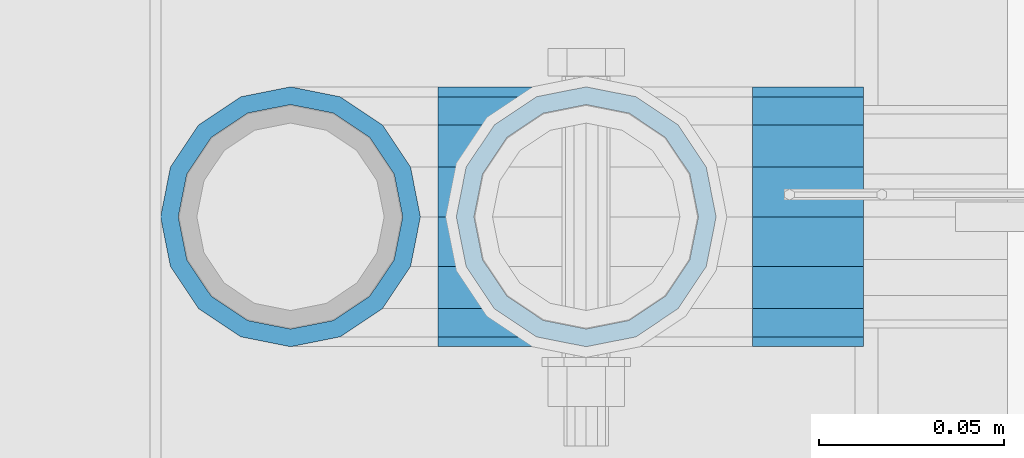
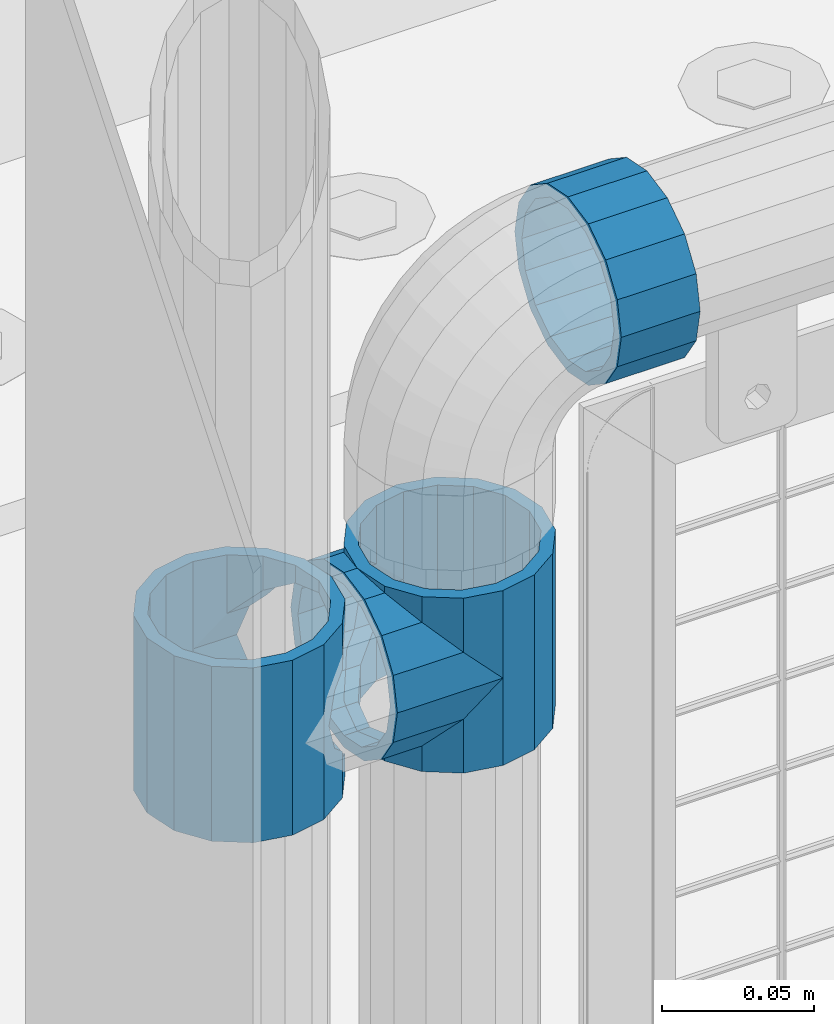
# One storey, part 145 of 247: 4 beams.
"""IFC2X3 building model written with IfcOpenShell, lengths in millimetres."""

from ifc_helpers import new_model, si_unit, frame, origin_with_axes, place, context, subcontext, project, spatial, faceted_brep, material, type_object, element, save


model = new_model("IFC2X3")

# Units and contexts
model_context = context("Model", 3, precision=1e-05, world=origin_with_axes())
body_context = subcontext(model_context, "Body", "Model", "MODEL_VIEW")
ifc_project = project(units=[si_unit("LENGTHUNIT", "METRE", prefix="MILLI"), si_unit("AREAUNIT", "SQUARE_METRE"), si_unit("VOLUMEUNIT", "CUBIC_METRE"), si_unit("MASSUNIT", "GRAM", prefix="KILO"), si_unit("TIMEUNIT", "SECOND"), si_unit("PLANEANGLEUNIT", "RADIAN"), si_unit("SOLIDANGLEUNIT", "STERADIAN"), si_unit("THERMODYNAMICTEMPERATUREUNIT", "DEGREE_CELSIUS"), si_unit("LUMINOUSINTENSITYUNIT", "LUMEN")], contexts=[model_context])

# Site, building, storey
site_placement = place(None, origin_with_axes())
site = spatial("IfcSite", under=ifc_project, at=site_placement, CompositionType="ELEMENT")
building_placement = place(site_placement, origin_with_axes())
building = spatial("IfcBuilding", under=site, at=building_placement, Name="Standard", CompositionType="ELEMENT")
storey_placement = place(building_placement, origin_with_axes())
storey = spatial("IfcBuildingStorey", under=building, at=storey_placement, Name="Undefined", CompositionType="ELEMENT", Elevation=0.0)

# Beams
ifc_material = material(Name="Misc_Undefined")
beam_type = type_object("IfcBeamType", PredefinedType="NOTDEFINED")
beam_1_placement = place(storey_placement, frame((621.0, 7664.5, 848.67), z_axis=(0.0, 1.0, 0.0), x_axis=(-1.0, 0.0, 0.0)))
element("IfcBeam", 1, at=beam_1_placement, inside=storey, type_object=beam_type, material=ifc_material, context=body_context, shape_type="Brep", body=[
    faceted_brep([(0.0, 0.0, -35.1499999999996), (13.4513226476338, -13.4513226476329, -32.4743655677721), (13.4513226476338, 13.4513226476329, -32.4743655677721), (27.1226768591096, -21.4606908090117, 21.4606908090118), (32.4743655677721, -26.8123795176755, 13.4513226476329), (32.4743655677721, -32.4743655677717, 13.4513226476329), (24.8548033587067, -24.8548033587072, 24.8548033587067), (24.8548033587067, -16.3810424080045, 24.8548033587067), (32.8397438117172, -28.0397438117175, 11.6144421722802), (35.1499999999996, -30.35, 0.0), (35.1499999999996, -35.15, 0.0), (32.4743655677721, -26.8123795176766, -13.4513226476329), (32.4743655677721, -32.4743655677717, -13.4513226476329), (32.8397438117172, -28.0397438117175, -11.6144421722802), (24.8548033587067, -16.3810424080045, -24.8548033587067), (24.8548033587067, -24.8548033587072, -24.8548033587067), (27.1226768591059, -21.4606908090117, -21.4606908090118), (20.0882031229885, -11.6144421722805, -28.0397438117179), (16.6306603983739, 0.0, -30.3500000000004), (20.0882031229885, 11.6144421722805, -28.0397438117179), (24.8548033587067, 16.3810424080029, -24.8548033587067), (24.8548033587067, 24.8548033587072, -24.8548033587067), (27.1226768591059, 21.4606908090117, -21.4606908090118), (32.4743655677721, 26.8123795176755, -13.4513226476329), (32.4743655677721, 32.4743655677717, -13.4513226476329), (32.8397438117172, 28.0397438117175, -11.6144421722802), (35.1499999999996, 30.35, 0.0), (35.1499999999996, 35.15, 0.0), (32.8397438117172, 28.0397438117175, 11.6144421722802), (32.4743655677721, 26.8123795176755, 13.4513226476329), (32.4743655677721, 32.4743655677717, 13.4513226476329), (27.1226768591096, 21.4606908090117, 21.4606908090118), (24.8548033587067, 16.3810424080046, 24.8548033587067), (24.8548033587067, 24.8548033587072, 24.8548033587067), (0.0, 0.0, 35.1499999999996), (13.4513226476338, 13.4513226476329, 32.4743655677721), (13.4513226476338, -13.4513226476329, 32.4743655677721), (20.0882031229812, 11.6144421722805, 28.0397438117179), (16.6306603983649, 0.0, 30.3500000000004), (20.0882031229812, -11.6144421722805, 28.0397438117179), (40.1500000000015, -35.15, 0.0), (40.1500000000015, -32.4743655677717, 13.4513226476329), (40.1500000000015, -24.8548033587072, 24.8548033587067), (40.1500000000015, -13.4513226476329, 32.4743655677721), (40.1500000000015, 0.0, 35.1499999999996), (40.1500000000015, -24.8548033587072, -24.8548033587067), (40.1500000000015, -32.4743655677717, -13.4513226476329), (40.1500000000015, -13.4513226476329, -32.4743655677721), (40.1500000000015, 0.0, -35.1499999999996), (40.1500000000015, 13.4513226476329, -32.4743655677721), (40.1500000000015, 24.8548033587072, -24.8548033587067), (40.1500000000015, 32.4743655677717, -13.4513226476329), (40.1500000000015, 35.15, 0.0), (40.1500000000015, 32.4743655677717, 13.4513226476329), (40.1500000000015, 24.8548033587072, 24.8548033587067), (40.1500000000015, 13.4513226476329, 32.4743655677721), (40.1500000000015, -21.4606908090117, 21.4606908090118), (40.1500000000015, -11.6144421722805, 28.0397438117179), (40.1500000000015, 0.0, 30.3500000000004), (40.1500000000015, 11.6144421722805, 28.0397438117179), (40.1500000000015, 21.4606908090117, 21.4606908090118), (40.1500000000015, 28.0397438117175, 11.6144421722802), (40.1500000000015, 30.35, 0.0), (40.1500000000015, 28.0397438117175, -11.6144421722802), (40.1500000000015, 21.4606908090117, -21.4606908090118), (40.1500000000015, 11.6144421722805, -28.0397438117179), (40.1500000000015, 0.0, -30.3500000000004), (40.1500000000015, -11.6144421722805, -28.0397438117179), (40.1500000000015, -21.4606908090117, -21.4606908090118), (40.1500000000015, -28.0397438117175, -11.6144421722802), (40.1500000000015, -30.35, 0.0), (40.1500000000015, -28.0397438117175, 11.6144421722802)], [[[0, 1, 2]], [[3, 4, 5, 6, 7]], [[8, 9, 10, 5, 4]], [[11, 12, 10, 9, 13]], [[14, 15, 12, 11, 16]], [[2, 1, 15, 14, 17, 18, 19, 20, 21]], [[21, 20, 22, 23, 24]], [[24, 23, 25, 26, 27]], [[27, 26, 28, 29, 30]], [[30, 29, 31, 32, 33]], [[34, 35, 36]], [[33, 32, 37, 38, 39, 7, 6, 36, 35]], [[40, 41, 5, 10]], [[41, 42, 6, 5]], [[42, 43, 36, 6]], [[43, 44, 34, 36]], [[45, 46, 12, 15]], [[47, 45, 15, 1]], [[48, 47, 1, 0]], [[49, 48, 0, 2]], [[50, 49, 2, 21]], [[51, 50, 21, 24]], [[52, 51, 24, 27]], [[53, 52, 27, 30]], [[54, 53, 30, 33]], [[55, 54, 33, 35]], [[44, 55, 35, 34]], [[46, 40, 10, 12]], [[45, 47, 48, 49, 50, 51, 52, 53, 54, 55, 44, 43, 42, 41, 40, 46], [56, 57, 58, 59, 60, 61, 62, 63, 64, 65, 66, 67, 68, 69, 70, 71]], [[59, 58, 38, 37]], [[60, 59, 37, 32, 31]], [[61, 60, 31, 29, 28]], [[62, 61, 28, 26]], [[63, 62, 26, 25]], [[22, 64, 63, 25, 23]], [[19, 65, 64, 22, 20]], [[66, 65, 19, 18]], [[67, 66, 18, 17]], [[68, 67, 17, 14, 16]], [[69, 68, 16, 11, 13]], [[70, 69, 13, 9]], [[71, 70, 9, 8]], [[3, 56, 71, 8, 4]], [[39, 57, 56, 3, 7]], [[58, 57, 39, 38]]]),
])
beam_2_placement = place(storey_placement, frame((541.0, 7664.5, 883.82), z_axis=(-1.0, 0.0, 0.0), x_axis=(0.0, 0.0, -1.0)))
element("IfcBeam", 2, at=beam_2_placement, inside=storey, type_object=beam_type, material=ifc_material, context=body_context, shape_type="Brep", body=[
    faceted_brep([(13.6893091909879, -21.4606908090118, -21.4606908090118), (13.6893091909879, -21.4606908090118, -27.1226768591077), (8.33762048232325, -13.4513226476329, -32.4743655677721), (7.11025618828211, -11.6144421722802, -32.839743811719), (7.11025618828211, -11.6144421722802, -28.0397438117179), (23.5355578277191, -28.0397438117179, -11.6144421722802), (23.5355578277191, -28.0397438117179, -20.0882031229885), (18.768957591997, -24.8548033587067, -24.8548033587067), (35.1499999999996, -30.35, 0.0), (35.1499999999996, -30.3500000000004, -16.6306603983739), (46.7644421722801, -28.0397438117179, -11.6144421722802), (46.7644421722801, -28.0397438117179, -20.0882031229885), (56.6106908090114, -21.4606908090118, -21.4606908090118), (56.6106908090114, -21.4606908090118, -27.1226768591077), (51.5310424080038, -24.8548033587067, -24.8548033587067), (63.1897438117172, -11.6144421722802, -28.0397438117179), (63.1897438117172, -11.6144421722802, -32.839743811719), (61.9623795176754, -13.4513226476329, -32.4743655677721), (65.4999999999997, 0.0, -30.3500000000004), (65.4999999999997, 0.0, -35.1499999999996), (63.1897438117172, 11.6144421722802, -28.0397438117179), (63.1897438117172, 11.6144421722802, -32.839743811719), (56.6106908090114, 21.4606908090118, -21.4606908090118), (56.6106908090114, 21.4606908090118, -27.1226768591096), (61.9623795176755, 13.4513226476329, -32.4743655677721), (46.7644421722801, 28.0397438117179, -11.6144421722802), (46.7644421722801, 28.0397438117179, -20.088203122983), (51.5310424080055, 24.8548033587067, -24.8548033587067), (35.1499999999996, 30.35, 0.0), (35.1499999999996, 30.3500000000004, -16.6306603983649), (23.5355578277192, 28.0397438117179, -11.6144421722802), (23.5355578277192, 28.0397438117179, -20.088203122983), (13.6893091909879, 21.4606908090118, -21.4606908090118), (13.6893091909879, 21.4606908090118, -27.1226768591096), (18.768957591997, 24.8548033587067, -24.8548033587067), (7.11025618828211, 11.6144421722802, -28.0397438117179), (7.11025618828211, 11.6144421722802, -32.839743811719), (8.33762048232387, 13.4513226476329, -32.4743655677721), (4.79999999999961, 0.0, -30.3500000000004), (4.79999999999961, 0.0, -35.1499999999996), (0.0, 21.4606908090118, 21.4606908090118), (0.0, 28.0397438117179, 11.6144421722802), (70.2999999999993, 28.0397438117179, 11.6144421722802), (70.2999999999993, 21.4606908090118, 21.4606908090118), (0.0, 11.6144421722802, 28.0397438117179), (70.2999999999993, 11.6144421722802, 28.0397438117179), (0.0, 0.0, 30.3500000000004), (70.2999999999993, 0.0, 30.3500000000004), (0.0, -11.6144421722802, 28.0397438117179), (70.2999999999993, -11.6144421722802, 28.0397438117179), (0.0, -21.4606908090118, 21.4606908090118), (70.2999999999993, -21.4606908090118, 21.4606908090118), (0.0, -28.0397438117179, 11.6144421722802), (70.2999999999993, -28.0397438117179, 11.6144421722802), (0.0, -24.8548033587067, -24.8548033587067), (0.0, -13.4513226476329, -32.4743655677721), (0.0, 0.0, -35.1499999999996), (0.0, -32.4743655677721, 13.4513226476338), (0.0, -35.1499999999996, 0.0), (70.2999999999993, -35.1499999999996, 0.0), (70.2999999999993, -32.4743655677721, 13.4513226476338), (0.0, -24.8548033587067, 24.8548033587067), (70.2999999999993, -24.8548033587067, 24.8548033587067), (0.0, -13.4513226476329, 32.4743655677721), (70.2999999999993, -13.4513226476329, 32.4743655677721), (0.0, 0.0, 35.1499999999996), (70.2999999999993, 0.0, 35.1499999999996), (0.0, 13.4513226476329, 32.4743655677721), (70.2999999999993, 13.4513226476329, 32.4743655677721), (0.0, 24.8548033587067, 24.8548033587067), (70.2999999999993, 24.8548033587067, 24.8548033587067), (0.0, 32.4743655677721, 13.4513226476338), (70.2999999999993, 32.4743655677721, 13.4513226476338), (0.0, 35.1499999999996, 0.0), (70.2999999999993, 35.1499999999996, 0.0), (0.0, 32.4743655677721, -13.4513226476338), (70.2999999999993, 32.4743655677721, -13.4513226476338), (70.2999999999993, -13.4513226476329, -32.4743655677721), (70.2999999999993, -24.8548033587067, -24.8548033587067), (70.2999999999993, 0.0, -35.1499999999996), (70.2999999999993, 13.4513226476329, -32.4743655677721), (70.2999999999993, 24.8548033587067, -24.8548033587067), (0.0, 24.8548033587067, -24.8548033587067), (0.0, 13.4513226476329, -32.4743655677721), (70.2999999999993, -32.4743655677721, -13.4513226476338), (0.0, -32.4743655677721, -13.4513226476338), (0.0, -28.0397438117179, -11.6144421722802), (0.0, -21.4606908090118, -21.4606908090118), (0.0, -11.6144421722802, -28.0397438117179), (0.0, 0.0, -30.3500000000004), (0.0, 11.6144421722802, -28.0397438117179), (0.0, 21.4606908090118, -21.4606908090118), (0.0, 28.0397438117179, -11.6144421722802), (0.0, 30.3500000000004, 0.0), (0.0, -30.3500000000004, 0.0), (70.2999999999993, 30.3500000000004, 0.0), (70.2999999999993, 28.0397438117179, -11.6144421722802), (70.2999999999993, 21.4606908090118, -21.4606908090118), (70.2999999999993, 11.6144421722802, -28.0397438117179), (70.2999999999993, 0.0, -30.3500000000004), (70.2999999999993, -11.6144421722802, -28.0397438117179), (70.2999999999993, -21.4606908090118, -21.4606908090118), (70.2999999999993, -28.0397438117179, -11.6144421722802), (70.2999999999993, -30.3500000000004, 0.0)], [[[0, 1, 2, 3, 4]], [[5, 6, 7, 1, 0]], [[8, 9, 6, 5]], [[10, 11, 9, 8]], [[12, 13, 14, 11, 10]], [[15, 16, 17, 13, 12]], [[18, 19, 16, 15]], [[20, 21, 19, 18]], [[22, 23, 24, 21, 20]], [[25, 26, 27, 23, 22]], [[28, 29, 26, 25]], [[30, 31, 29, 28]], [[32, 33, 34, 31, 30]], [[35, 36, 37, 33, 32]], [[38, 39, 36, 35]], [[4, 3, 39, 38]], [[40, 41, 42, 43]], [[44, 40, 43, 45]], [[46, 44, 45, 47]], [[48, 46, 47, 49]], [[50, 48, 49, 51]], [[52, 50, 51, 53]], [[54, 55, 2, 1, 7]], [[55, 56, 39, 3, 2]], [[57, 58, 59, 60]], [[61, 57, 60, 62]], [[63, 61, 62, 64]], [[65, 63, 64, 66]], [[67, 65, 66, 68]], [[69, 67, 68, 70]], [[71, 69, 70, 72]], [[73, 71, 72, 74]], [[75, 73, 74, 76]], [[17, 77, 78, 14, 13]], [[19, 79, 77, 17, 16]], [[80, 79, 19, 21, 24]], [[81, 80, 24, 23, 27]], [[34, 82, 75, 76, 81, 27, 26, 29, 31]], [[37, 83, 82, 34, 33]], [[39, 56, 83, 37, 36]], [[14, 78, 84, 85, 54, 7, 6, 9, 11]], [[58, 85, 84, 59]], [[57, 61, 63, 65, 67, 69, 71, 73, 75, 82, 83, 56, 55, 54, 85, 58], [86, 87, 88, 89, 90, 91, 92, 93, 41, 40, 44, 46, 48, 50, 52, 94]], [[90, 89, 38, 35]], [[91, 90, 35, 32]], [[92, 91, 32, 30]], [[93, 92, 30, 28]], [[41, 93, 28, 95, 42]], [[96, 95, 28, 25]], [[97, 96, 25, 22]], [[98, 97, 22, 20]], [[99, 98, 20, 18]], [[100, 99, 18, 15]], [[101, 100, 15, 12]], [[102, 101, 12, 10]], [[103, 102, 10, 8]], [[78, 77, 79, 80, 81, 76, 74, 72, 70, 68, 66, 64, 62, 60, 59, 84], [51, 49, 47, 45, 43, 42, 95, 96, 97, 98, 99, 100, 101, 102, 103, 53]], [[8, 94, 52, 53, 103]], [[86, 94, 8, 5]], [[87, 86, 5, 0]], [[88, 87, 0, 4]], [[89, 88, 4, 38]]]),
])
beam_3_placement = place(storey_placement, frame((621.0, 7664.5, 883.82), z_axis=(1.0, 0.0, 0.0), x_axis=(0.0, 0.0, -1.0)))
element("IfcBeam", 3, at=beam_3_placement, inside=storey, type_object=beam_type, material=ifc_material, context=body_context, shape_type="Brep", body=[
    faceted_brep([(46.7644421722801, 28.0397438117179, -11.6144421722802), (46.7644421722801, 28.0397438117179, -20.088203122983), (51.5310424080055, 24.8548033587067, -24.8548033587067), (56.6106908090114, 21.4606908090118, -27.1226768591096), (56.6106908090114, 21.4606908090118, -21.4606908090118), (61.9623795176755, 13.4513226476329, -32.4743655677721), (63.1897438117172, 11.6144421722802, -32.839743811719), (63.1897438117172, 11.6144421722802, -28.0397438117179), (65.4999999999997, 0.0, -35.1499999999996), (65.4999999999997, 0.0, -30.3500000000004), (63.1897438117172, -11.6144421722802, -32.839743811719), (63.1897438117172, -11.6144421722802, -28.0397438117179), (61.9623795176754, -13.4513226476329, -32.4743655677721), (56.6106908090114, -21.4606908090118, -27.1226768591077), (56.6106908090114, -21.4606908090118, -21.4606908090118), (51.5310424080038, -24.8548033587067, -24.8548033587067), (46.7644421722801, -28.0397438117179, -20.0882031229885), (46.7644421722801, -28.0397438117179, -11.6144421722802), (35.1499999999996, -30.3500000000004, -16.6306603983739), (35.1499999999996, -30.35, 0.0), (23.5355578277191, -28.0397438117179, -20.0882031229885), (23.5355578277191, -28.0397438117179, -11.6144421722802), (18.768957591997, -24.8548033587067, -24.8548033587067), (13.6893091909879, -21.4606908090118, -27.1226768591077), (13.6893091909879, -21.4606908090118, -21.4606908090118), (8.33762048232325, -13.4513226476329, -32.4743655677721), (7.11025618828211, -11.6144421722802, -32.839743811719), (7.11025618828211, -11.6144421722802, -28.0397438117179), (4.79999999999961, 0.0, -35.1499999999996), (4.79999999999961, 0.0, -30.3500000000004), (7.11025618828211, 11.6144421722802, -32.839743811719), (7.11025618828211, 11.6144421722802, -28.0397438117179), (8.33762048232387, 13.4513226476329, -32.4743655677721), (13.6893091909879, 21.4606908090118, -27.1226768591096), (13.6893091909879, 21.4606908090118, -21.4606908090118), (18.768957591997, 24.8548033587067, -24.8548033587067), (23.5355578277192, 28.0397438117179, -20.088203122983), (23.5355578277192, 28.0397438117179, -11.6144421722802), (35.1499999999996, 30.3500000000004, -16.6306603983649), (35.1499999999996, 30.35, 0.0), (0.0, 32.4743655677721, -13.4513226476338), (0.0, 35.1499999999996, 0.0), (70.2999999999993, 35.1499999999996, 0.0), (70.2999999999993, 32.4743655677721, -13.4513226476338), (0.0, 32.4743655677721, 13.4513226476338), (70.2999999999993, 32.4743655677721, 13.4513226476338), (0.0, 24.8548033587067, 24.8548033587067), (70.2999999999993, 24.8548033587067, 24.8548033587067), (0.0, 13.4513226476329, 32.4743655677721), (70.2999999999993, 13.4513226476329, 32.4743655677721), (0.0, 0.0, 35.1499999999996), (70.2999999999993, 0.0, 35.1499999999996), (0.0, -13.4513226476329, 32.4743655677721), (70.2999999999993, -13.4513226476329, 32.4743655677721), (0.0, -24.8548033587067, 24.8548033587067), (70.2999999999993, -24.8548033587067, 24.8548033587067), (0.0, -32.4743655677721, 13.4513226476338), (70.2999999999993, -32.4743655677721, 13.4513226476338), (0.0, -35.1499999999996, 0.0), (70.2999999999993, -35.1499999999996, 0.0), (70.2999999999993, -30.3500000000004, 0.0), (70.2999999999993, -28.0397438117179, -11.6144421722802), (70.2999999999993, -21.4606908090118, -21.4606908090118), (70.2999999999993, -11.6144421722802, -28.0397438117179), (70.2999999999993, 0.0, -30.3500000000004), (70.2999999999993, 11.6144421722802, -28.0397438117179), (70.2999999999993, 21.4606908090118, -21.4606908090118), (70.2999999999993, 28.0397438117179, -11.6144421722802), (0.0, -28.0397438117179, -11.6144421722802), (0.0, -30.3500000000004, 0.0), (0.0, -21.4606908090118, -21.4606908090118), (0.0, -11.6144421722802, -28.0397438117179), (0.0, 0.0, -30.3500000000004), (0.0, 11.6144421722802, -28.0397438117179), (0.0, 21.4606908090118, -21.4606908090118), (0.0, 28.0397438117179, -11.6144421722802), (0.0, 30.3500000000004, 0.0), (70.2999999999993, 30.3500000000004, 0.0), (0.0, 28.0397438117179, 11.6144421722802), (70.2999999999993, 28.0397438117179, 11.6144421722802), (0.0, 21.4606908090118, 21.4606908090118), (70.2999999999993, 21.4606908090118, 21.4606908090118), (0.0, 11.6144421722802, 28.0397438117179), (70.2999999999993, 11.6144421722802, 28.0397438117179), (0.0, 0.0, 30.3500000000004), (70.2999999999993, 0.0, 30.3500000000004), (0.0, -11.6144421722802, 28.0397438117179), (70.2999999999993, -11.6144421722802, 28.0397438117179), (0.0, -21.4606908090118, 21.4606908090118), (70.2999999999993, -21.4606908090118, 21.4606908090118), (0.0, -28.0397438117179, 11.6144421722802), (70.2999999999993, -28.0397438117179, 11.6144421722802), (70.2999999999993, -24.8548033587067, -24.8548033587067), (70.2999999999993, -13.4513226476329, -32.4743655677721), (70.2999999999993, 0.0, -35.1499999999996), (70.2999999999993, 13.4513226476329, -32.4743655677721), (70.2999999999993, 24.8548033587067, -24.8548033587067), (70.2999999999993, -32.4743655677721, -13.4513226476338), (0.0, -32.4743655677721, -13.4513226476338), (0.0, 24.8548033587067, -24.8548033587067), (0.0, 13.4513226476329, -32.4743655677721), (0.0, 0.0, -35.1499999999996), (0.0, -13.4513226476329, -32.4743655677721), (0.0, -24.8548033587067, -24.8548033587067)], [[[0, 1, 2, 3, 4]], [[4, 3, 5, 6, 7]], [[7, 6, 8, 9]], [[9, 8, 10, 11]], [[11, 10, 12, 13, 14]], [[14, 13, 15, 16, 17]], [[17, 16, 18, 19]], [[19, 18, 20, 21]], [[21, 20, 22, 23, 24]], [[24, 23, 25, 26, 27]], [[27, 26, 28, 29]], [[29, 28, 30, 31]], [[31, 30, 32, 33, 34]], [[34, 33, 35, 36, 37]], [[37, 36, 38, 39]], [[39, 38, 1, 0]], [[40, 41, 42, 43]], [[41, 44, 45, 42]], [[44, 46, 47, 45]], [[46, 48, 49, 47]], [[48, 50, 51, 49]], [[50, 52, 53, 51]], [[52, 54, 55, 53]], [[54, 56, 57, 55]], [[56, 58, 59, 57]], [[60, 61, 17, 19]], [[61, 62, 14, 17]], [[62, 63, 11, 14]], [[63, 64, 9, 11]], [[64, 65, 7, 9]], [[65, 66, 4, 7]], [[66, 67, 0, 4]], [[68, 69, 19, 21]], [[70, 68, 21, 24]], [[71, 70, 24, 27]], [[72, 71, 27, 29]], [[73, 72, 29, 31]], [[74, 73, 31, 34]], [[75, 74, 34, 37]], [[76, 75, 37, 39]], [[67, 77, 39, 0]], [[78, 76, 39, 77, 79]], [[80, 78, 79, 81]], [[82, 80, 81, 83]], [[84, 82, 83, 85]], [[86, 84, 85, 87]], [[88, 86, 87, 89]], [[90, 88, 89, 91]], [[19, 69, 90, 91, 60]], [[92, 93, 94, 95, 96, 43, 42, 45, 47, 49, 51, 53, 55, 57, 59, 97], [89, 87, 85, 83, 81, 79, 77, 67, 66, 65, 64, 63, 62, 61, 60, 91]], [[58, 98, 97, 59]], [[56, 54, 52, 50, 48, 46, 44, 41, 40, 99, 100, 101, 102, 103, 98, 58], [68, 70, 71, 72, 73, 74, 75, 76, 78, 80, 82, 84, 86, 88, 90, 69]], [[32, 100, 99, 35, 33]], [[28, 101, 100, 32, 30]], [[102, 101, 28, 26, 25]], [[103, 102, 25, 23, 22]], [[15, 92, 97, 98, 103, 22, 20, 18, 16]], [[12, 93, 92, 15, 13]], [[8, 94, 93, 12, 10]], [[95, 94, 8, 6, 5]], [[96, 95, 5, 3, 2]], [[35, 99, 40, 43, 96, 2, 1, 38, 36]]]),
])
beam_4_placement = place(storey_placement, frame((666.0, 7664.5, 969.849999999999), z_axis=(0.0, 0.0, 1.0), x_axis=(1.0, 0.0, 0.0)))
element("IfcBeam", 4, at=beam_4_placement, inside=storey, type_object=beam_type, material=ifc_material, context=body_context, shape_type="Brep", body=[
    faceted_brep([(0.0, -30.3500000000004, 0.0), (0.0, -28.0397438117179, 11.6144421722802), (30.0, -28.0397438117179, 11.6144421722805), (30.0, -30.3500000000004, 0.0), (0.0, -21.4606908090118, 21.4606908090118), (30.0, -21.4606908090118, 21.4606908090117), (0.0, -11.6144421722802, 28.0397438117179), (30.0, -11.6144421722802, 28.0397438117175), (0.0, 0.0, 30.3500000000004), (30.0, 0.0, 30.35), (0.0, 11.6144421722802, 28.0397438117179), (30.0, 11.6144421722802, 28.0397438117175), (0.0, 21.4606908090118, 21.4606908090118), (30.0, 21.4606908090118, 21.4606908090117), (0.0, 28.0397438117179, 11.6144421722802), (30.0, 28.0397438117179, 11.6144421722805), (0.0, 30.3500000000004, 0.0), (30.0, 30.3500000000004, 0.0), (0.0, 28.0397438117179, -11.6144421722802), (30.0, 28.0397438117179, -11.6144421722805), (0.0, 21.4606908090118, -21.4606908090118), (30.0, 21.4606908090118, -21.4606908090117), (0.0, 11.6144421722802, -28.0397438117179), (30.0, 11.6144421722802, -28.0397438117175), (0.0, 0.0, -30.3500000000004), (30.0, 0.0, -30.35), (0.0, -11.6144421722802, -28.0397438117179), (30.0, -11.6144421722802, -28.0397438117175), (0.0, -21.4606908090118, -21.4606908090118), (30.0, -21.4606908090118, -21.4606908090117), (0.0, -28.0397438117179, -11.6144421722802), (30.0, -28.0397438117179, -11.6144421722805), (0.0, -35.1499999999996, 0.0), (0.0, -32.4743655677721, -13.4513226476338), (30.0, -32.4743655677721, -13.4513226476329), (30.0, -35.1499999999996, 0.0), (0.0, -24.8548033587067, -24.8548033587067), (30.0, -24.8548033587067, -24.8548033587072), (0.0, -13.4513226476329, -32.4743655677721), (30.0, -13.4513226476329, -32.4743655677717), (0.0, 0.0, -35.1499999999996), (30.0, 0.0, -35.15), (0.0, 13.4513226476329, -32.4743655677721), (30.0, 13.4513226476329, -32.4743655677717), (0.0, 24.8548033587067, -24.8548033587067), (30.0, 24.8548033587067, -24.8548033587072), (0.0, 32.4743655677721, -13.4513226476338), (30.0, 32.4743655677721, -13.4513226476329), (0.0, 35.1499999999996, 0.0), (30.0, 35.1499999999996, 0.0), (0.0, 32.4743655677721, 13.4513226476338), (30.0, 32.4743655677721, 13.4513226476329), (0.0, 24.8548033587067, 24.8548033587067), (30.0, 24.8548033587067, 24.8548033587072), (0.0, 13.4513226476329, 32.4743655677721), (30.0, 13.4513226476329, 32.4743655677717), (0.0, 0.0, 35.1499999999996), (30.0, 0.0, 35.15), (0.0, -13.4513226476329, 32.4743655677721), (30.0, -13.4513226476329, 32.4743655677717), (0.0, -24.8548033587067, 24.8548033587067), (30.0, -24.8548033587067, 24.8548033587072), (0.0, -32.4743655677721, 13.4513226476338), (30.0, -32.4743655677721, 13.4513226476329)], [[[0, 1, 2, 3]], [[1, 4, 5, 2]], [[4, 6, 7, 5]], [[6, 8, 9, 7]], [[8, 10, 11, 9]], [[10, 12, 13, 11]], [[12, 14, 15, 13]], [[14, 16, 17, 15]], [[16, 18, 19, 17]], [[18, 20, 21, 19]], [[20, 22, 23, 21]], [[22, 24, 25, 23]], [[24, 26, 27, 25]], [[26, 28, 29, 27]], [[28, 30, 31, 29]], [[30, 0, 3, 31]], [[32, 33, 34, 35]], [[33, 36, 37, 34]], [[36, 38, 39, 37]], [[38, 40, 41, 39]], [[40, 42, 43, 41]], [[42, 44, 45, 43]], [[44, 46, 47, 45]], [[46, 48, 49, 47]], [[48, 50, 51, 49]], [[50, 52, 53, 51]], [[52, 54, 55, 53]], [[54, 56, 57, 55]], [[56, 58, 59, 57]], [[58, 60, 61, 59]], [[60, 62, 63, 61]], [[62, 32, 35, 63]], [[37, 39, 41, 43, 45, 47, 49, 51, 53, 55, 57, 59, 61, 63, 35, 34], [5, 7, 9, 11, 13, 15, 17, 19, 21, 23, 25, 27, 29, 31, 3, 2]], [[62, 60, 58, 56, 54, 52, 50, 48, 46, 44, 42, 40, 38, 36, 33, 32], [30, 28, 26, 24, 22, 20, 18, 16, 14, 12, 10, 8, 6, 4, 1, 0]]]),
])

save(model, "model.ifc")
